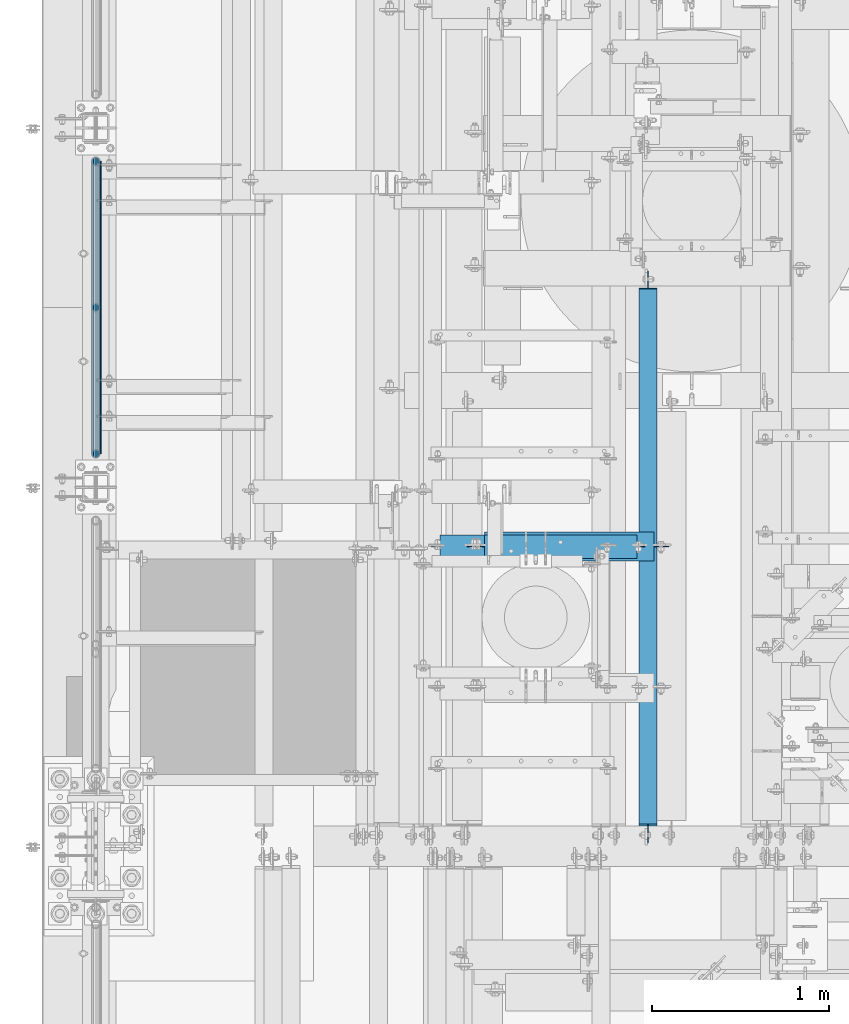
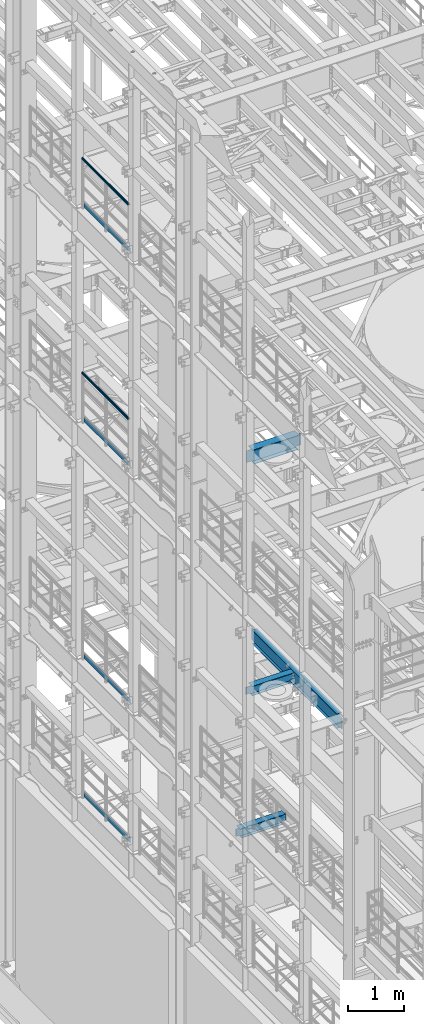
# One storey, part 1019 of 1876: 10 beams, 8 elements without a shape of their own.
"""IFC2X3 building model written with IfcOpenShell, lengths in millimetres."""

from ifc_helpers import new_model, si_unit, frame, origin_with_axes, place, context, subcontext, project, spatial, faceted_brep, material, type_object, element, aggregate, save


model = new_model("IFC2X3")

# Units and contexts
model_context = context("Model", 3, precision=1e-05, world=origin_with_axes())
body_context = subcontext(model_context, "Body", "Model", "MODEL_VIEW")
ifc_project = project(units=[si_unit("LENGTHUNIT", "METRE", prefix="MILLI"), si_unit("AREAUNIT", "SQUARE_METRE"), si_unit("VOLUMEUNIT", "CUBIC_METRE"), si_unit("MASSUNIT", "GRAM", prefix="KILO"), si_unit("TIMEUNIT", "SECOND"), si_unit("PLANEANGLEUNIT", "RADIAN"), si_unit("SOLIDANGLEUNIT", "STERADIAN"), si_unit("THERMODYNAMICTEMPERATUREUNIT", "DEGREE_CELSIUS"), si_unit("LUMINOUSINTENSITYUNIT", "LUMEN")], contexts=[model_context])

# Site, building, storey
site_placement = place(None, origin_with_axes())
site = spatial("IfcSite", under=ifc_project, at=site_placement, CompositionType="ELEMENT")
building_placement = place(site_placement, origin_with_axes())
building = spatial("IfcBuilding", under=site, at=building_placement, Name="Undefined", CompositionType="ELEMENT")
storey_placement = place(building_placement, origin_with_axes())
storey = spatial("IfcBuildingStorey", under=building, at=storey_placement, Name="Undefined", CompositionType="ELEMENT", Elevation=0.0)

# Assembly, beam
assembly_1_placement = place(storey_placement, origin_with_axes())
assembly_1 = element("IfcElementAssembly", 1, at=assembly_1_placement, inside=storey, Name="RAIL", AssemblyPlace="NOTDEFINED", PredefinedType="RIGID_FRAME")
ifc_material_1 = material()
beam_type_1 = type_object("IfcBeamType", Name="PIPE1-1/2SCH40", PredefinedType="NOTDEFINED")
beam_1_placement = place(assembly_1_placement, frame((-1.81898940354586e-12, 3721.1, 19059.525), z_axis=(0.0, 0.0, -1.0), x_axis=(0.0, 1.0, 0.0)))
beam_1 = element("IfcBeam", 2, at=beam_1_placement, type_object=beam_type_1, material=ifc_material_1, Name="RAIL", ObjectType="PIPE1-1/2SCH40", context=body_context, shape_type="Brep", body=[
    faceted_brep([(24.1300000000001, -20.4469999999999, 0.0), (34.3535000000002, -17.7076214311803, 10.2235000000001), (1667.4465, -17.7076214311801, 10.2235000000001), (1677.67, -20.4470000000001, 0.0), (41.8376214311802, -10.2235000000001, 17.7076214311819), (1659.96237856882, -10.2235000000001, 17.7076214311819), (44.5770000000002, 0.0, 20.4470000000001), (1657.223, 0.0, 20.4470000000001), (41.8376214311802, 10.2235000000001, 17.7076214311819), (1659.96237856882, 10.2235000000001, 17.7076214311819), (34.3535000000002, 17.7076214311803, 10.2235000000001), (1667.4465, 17.7076214311801, 10.2235000000001), (24.1300000000001, 20.4469999999999, 0.0), (1677.67, 20.4470000000001, 0.0), (13.9065000000001, 17.7076214311803, -10.2235000000001), (1687.8935, 17.7076214311801, -10.2235000000001), (6.42237856882002, 10.2235000000001, -17.7076214311819), (1695.37762143118, 10.2235000000001, -17.7076214311819), (3.68299999999999, 0.0, -20.4470000000001), (1698.117, 0.0, -20.4470000000001), (6.42237856882002, -10.2235000000001, -17.7076214311819), (1695.37762143118, -10.2235000000001, -17.7076214311819), (13.9065000000001, -17.7076214311803, -10.2235000000001), (1687.8935, -17.7076214311801, -10.2235000000001), (24.1299999999854, -24.1299999999992, 0.0), (12.0650000000064, -20.8971929933177, -12.0649999999987), (1689.735, -20.8971929933186, -12.0649999999987), (1677.67, -24.1300000000001, 0.0), (3.23280700668147, -12.0650000000001, -20.8971929933177), (1698.56719299332, -12.0649999999996, -20.8971929933177), (-1.45519152283669e-11, 0.0, -24.130000000001), (1701.8, 0.0, -24.130000000001), (3.23280700668147, 12.0650000000001, -20.8971929933177), (1698.56719299332, 12.0649999999996, -20.8971929933177), (12.0650000000064, 20.8971929933177, -12.0649999999987), (1689.735, 20.8971929933186, -12.0649999999987), (24.1300000000047, 24.1299999999992, 0.0), (1677.67, 24.1300000000001, 0.0), (36.1949999999997, 20.8971929933184, 12.0649999999987), (1665.605, 20.8971929933186, 12.0649999999987), (45.0271929933187, 12.0650000000001, 20.8971929933177), (1656.77280700668, 12.0649999999996, 20.8971929933177), (48.2600000000002, 0.0, 24.130000000001), (1653.54, 0.0, 24.130000000001), (45.0271929933187, -12.0650000000001, 20.8971929933177), (1656.77280700668, -12.0649999999996, 20.8971929933177), (36.1949999999997, -20.8971929933184, 12.0649999999987), (1665.605, -20.8971929933186, 12.0649999999987)], [[[0, 1, 2, 3]], [[1, 4, 5, 2]], [[4, 6, 7, 5]], [[6, 8, 9, 7]], [[8, 10, 11, 9]], [[10, 12, 13, 11]], [[12, 14, 15, 13]], [[14, 16, 17, 15]], [[16, 18, 19, 17]], [[18, 20, 21, 19]], [[20, 22, 23, 21]], [[22, 0, 3, 23]], [[24, 25, 26, 27]], [[25, 28, 29, 26]], [[28, 30, 31, 29]], [[30, 32, 33, 31]], [[32, 34, 35, 33]], [[34, 36, 37, 35]], [[36, 38, 39, 37]], [[38, 40, 41, 39]], [[40, 42, 43, 41]], [[42, 44, 45, 43]], [[44, 46, 47, 45]], [[46, 24, 27, 47]], [[29, 31, 33, 35, 37, 39, 41, 43, 45, 47, 27, 26], [5, 7, 9, 11, 13, 15, 17, 19, 21, 23, 3, 2]], [[46, 44, 42, 40, 38, 36, 34, 32, 30, 28, 25, 24], [22, 20, 18, 16, 14, 12, 10, 8, 6, 4, 1, 0]]]),
])

assembly_2_placement = place(storey_placement, origin_with_axes())
assembly_2 = element("IfcElementAssembly", 3, at=assembly_2_placement, inside=storey, Name="RAIL", AssemblyPlace="NOTDEFINED", PredefinedType="RIGID_FRAME")
beam_2_placement = place(assembly_2_placement, frame((-1.81898940354586e-12, 3721.1, 14385.925), z_axis=(0.0, 0.0, -1.0), x_axis=(0.0, 1.0, 0.0)))
beam_2 = element("IfcBeam", 4, at=beam_2_placement, type_object=beam_type_1, material=ifc_material_1, Name="RAIL", ObjectType="PIPE1-1/2SCH40", context=body_context, shape_type="Brep", body=[
    faceted_brep([(24.1300000000001, -20.4469999999999, 0.0), (34.3535000000002, -17.7076214311803, 10.2235000000001), (1667.4465, -17.7076214311801, 10.2235000000001), (1677.67, -20.4470000000001, 0.0), (41.8376214311802, -10.2235000000001, 17.7076214311819), (1659.96237856882, -10.2235000000001, 17.7076214311819), (44.5770000000002, 0.0, 20.4470000000001), (1657.223, 0.0, 20.4470000000001), (41.8376214311802, 10.2235000000001, 17.7076214311819), (1659.96237856882, 10.2235000000001, 17.7076214311819), (34.3535000000002, 17.7076214311803, 10.2235000000001), (1667.4465, 17.7076214311801, 10.2235000000001), (24.1300000000001, 20.4469999999999, 0.0), (1677.67, 20.4470000000001, 0.0), (13.9065000000001, 17.7076214311803, -10.2235000000001), (1687.8935, 17.7076214311801, -10.2235000000001), (6.42237856882002, 10.2235000000001, -17.7076214311819), (1695.37762143118, 10.2235000000001, -17.7076214311819), (3.68299999999999, 0.0, -20.4470000000001), (1698.117, 0.0, -20.4470000000001), (6.42237856882002, -10.2235000000001, -17.7076214311819), (1695.37762143118, -10.2235000000001, -17.7076214311819), (13.9065000000001, -17.7076214311803, -10.2235000000001), (1687.8935, -17.7076214311801, -10.2235000000001), (24.1299999999854, -24.1299999999992, 0.0), (12.0650000000064, -20.8971929933177, -12.0649999999987), (1689.735, -20.8971929933186, -12.0649999999987), (1677.67, -24.1300000000001, 0.0), (3.23280700668147, -12.0650000000001, -20.8971929933177), (1698.56719299332, -12.0649999999996, -20.8971929933177), (-1.45519152283669e-11, 0.0, -24.130000000001), (1701.8, 0.0, -24.130000000001), (3.23280700668147, 12.0650000000001, -20.8971929933177), (1698.56719299332, 12.0649999999996, -20.8971929933177), (12.0650000000064, 20.8971929933177, -12.0649999999987), (1689.735, 20.8971929933186, -12.0649999999987), (24.1300000000047, 24.1299999999992, 0.0), (1677.67, 24.1300000000001, 0.0), (36.1949999999997, 20.8971929933184, 12.0649999999987), (1665.605, 20.8971929933186, 12.0649999999987), (45.0271929933187, 12.0650000000001, 20.8971929933177), (1656.77280700668, 12.0649999999996, 20.8971929933177), (48.2600000000002, 0.0, 24.130000000001), (1653.54, 0.0, 24.130000000001), (45.0271929933187, -12.0650000000001, 20.8971929933177), (1656.77280700668, -12.0649999999996, 20.8971929933177), (36.1949999999997, -20.8971929933184, 12.0649999999987), (1665.605, -20.8971929933186, 12.0649999999987)], [[[0, 1, 2, 3]], [[1, 4, 5, 2]], [[4, 6, 7, 5]], [[6, 8, 9, 7]], [[8, 10, 11, 9]], [[10, 12, 13, 11]], [[12, 14, 15, 13]], [[14, 16, 17, 15]], [[16, 18, 19, 17]], [[18, 20, 21, 19]], [[20, 22, 23, 21]], [[22, 0, 3, 23]], [[24, 25, 26, 27]], [[25, 28, 29, 26]], [[28, 30, 31, 29]], [[30, 32, 33, 31]], [[32, 34, 35, 33]], [[34, 36, 37, 35]], [[36, 38, 39, 37]], [[38, 40, 41, 39]], [[40, 42, 43, 41]], [[42, 44, 45, 43]], [[44, 46, 47, 45]], [[46, 24, 27, 47]], [[29, 31, 33, 35, 37, 39, 41, 43, 45, 47, 27, 26], [5, 7, 9, 11, 13, 15, 17, 19, 21, 23, 3, 2]], [[46, 44, 42, 40, 38, 36, 34, 32, 30, 28, 25, 24], [22, 20, 18, 16, 14, 12, 10, 8, 6, 4, 1, 0]]]),
])

# Beam
ifc_material_2 = material(Name="STEEL/A36")
beam_type_2 = type_object("IfcBeamType", PredefinedType="NOTDEFINED")
beam_3_placement = place(assembly_1_placement, frame((27.3049999999948, 3745.23, 18049.875), z_axis=(0.0, 0.0, 1.0), x_axis=(0.0, 1.0, 0.0)))
beam_3 = element("IfcBeam", 5, at=beam_3_placement, type_object=beam_type_2, material=ifc_material_2, Name="PLATE", context=body_context, shape_type="Brep", body=[
    faceted_brep([(0.0, 3.17500000000018, -50.8000000000002), (0.0, 3.17500000000018, 50.8000000000002), (1653.54, 3.175, 50.7999999999993), (1653.54, 3.175, -50.7999999999993), (0.0, -3.17500000000018, 50.8000000000002), (1653.54, -3.175, 50.7999999999993), (0.0, -3.17500000000018, -50.8000000000002), (1653.54, -3.175, -50.7999999999993)], [[[0, 1, 2, 3]], [[1, 4, 5, 2]], [[4, 6, 7, 5]], [[6, 0, 3, 7]], [[5, 7, 3, 2]], [[6, 4, 1, 0]]]),
])

aggregate(assembly_1, [beam_3, beam_1])

beam_4_placement = place(assembly_2_placement, frame((27.3049999999948, 3745.23, 13376.275), z_axis=(0.0, 0.0, 1.0), x_axis=(0.0, 1.0, 0.0)))
beam_4 = element("IfcBeam", 6, at=beam_4_placement, type_object=beam_type_2, material=ifc_material_2, Name="PLATE", context=body_context, shape_type="Brep", body=[
    faceted_brep([(0.0, 3.17500000000018, -50.8000000000002), (0.0, 3.17500000000018, 50.8000000000002), (1653.54, 3.175, 50.7999999999993), (1653.54, 3.175, -50.7999999999993), (0.0, -3.17500000000018, 50.8000000000002), (1653.54, -3.175, 50.7999999999993), (0.0, -3.17500000000018, -50.8000000000002), (1653.54, -3.175, -50.7999999999993)], [[[0, 1, 2, 3]], [[1, 4, 5, 2]], [[4, 6, 7, 5]], [[6, 0, 3, 7]], [[5, 7, 3, 2]], [[6, 4, 1, 0]]]),
])

aggregate(assembly_2, [beam_4, beam_2])

# Assembly, beam
assembly_3_placement = place(storey_placement, origin_with_axes())
assembly_3 = element("IfcElementAssembly", 7, at=assembly_3_placement, inside=storey, Name="RAIL", AssemblyPlace="NOTDEFINED", PredefinedType="RIGID_FRAME")
beam_5_placement = place(assembly_3_placement, frame((27.3049999999948, 3745.23000000001, 8220.075), z_axis=(0.0, 0.0, 1.0), x_axis=(0.0, 1.0, 0.0)))
beam_5 = element("IfcBeam", 8, at=beam_5_placement, type_object=beam_type_2, material=ifc_material_2, Name="PLATE", context=body_context, shape_type="Brep", body=[
    faceted_brep([(0.0, 3.17500000000018, -50.8000000000002), (0.0, 3.17500000000018, 50.8000000000002), (1653.54, 3.175, 50.7999999999993), (1653.54, 3.175, -50.7999999999993), (0.0, -3.17500000000018, 50.8000000000002), (1653.54, -3.175, 50.7999999999993), (0.0, -3.17500000000018, -50.8000000000002), (1653.54, -3.175, -50.7999999999993)], [[[0, 1, 2, 3]], [[1, 4, 5, 2]], [[4, 6, 7, 5]], [[6, 0, 3, 7]], [[5, 7, 3, 2]], [[6, 4, 1, 0]]]),
])
aggregate(assembly_3, [beam_5])

assembly_4_placement = place(storey_placement, origin_with_axes())
assembly_4 = element("IfcElementAssembly", 9, at=assembly_4_placement, inside=storey, Name="RAIL", AssemblyPlace="NOTDEFINED", PredefinedType="RIGID_FRAME")
beam_6_placement = place(assembly_4_placement, frame((27.3049999999948, 3745.23, 5197.475), z_axis=(0.0, 0.0, 1.0), x_axis=(0.0, 1.0, 0.0)))
beam_6 = element("IfcBeam", 10, at=beam_6_placement, type_object=beam_type_2, material=ifc_material_2, Name="PLATE", context=body_context, shape_type="Brep", body=[
    faceted_brep([(0.0, 3.17500000000018, -50.8000000000002), (0.0, 3.17500000000018, 50.8000000000002), (1653.54, 3.175, 50.7999999999993), (1653.54, 3.175, -50.7999999999993), (0.0, -3.17500000000018, 50.8000000000002), (1653.54, -3.175, 50.7999999999993), (0.0, -3.17500000000018, -50.8000000000002), (1653.54, -3.175, -50.7999999999993)], [[[0, 1, 2, 3]], [[1, 4, 5, 2]], [[4, 6, 7, 5]], [[6, 0, 3, 7]], [[5, 7, 3, 2]], [[6, 4, 1, 0]]]),
])
aggregate(assembly_4, [beam_6])

assembly_5_placement = place(storey_placement, origin_with_axes())
assembly_5 = element("IfcElementAssembly", 11, at=assembly_5_placement, inside=storey, Name="BEAM", AssemblyPlace="NOTDEFINED", PredefinedType="RIGID_FRAME")
ifc_material_3 = material(Name="STEEL/A992")
beam_type_3 = type_object("IfcBeamType", Name="W12X16", PredefinedType="NOTDEFINED")
beam_7_placement = place(assembly_5_placement, frame((3124.2, 1524.0, 8001.0), z_axis=(0.0, 0.0, 1.0), x_axis=(0.0, 1.0, 0.0)))
beam_7 = element("IfcBeam", 12, at=beam_7_placement, type_object=beam_type_3, material=ifc_material_3, Name="BEAM", ObjectType="W12X16", context=body_context, shape_type="Brep", body=[
    faceted_brep([(3158.33125000001, -3.17500000000018, -146.05), (3158.33125000001, -50.8000000000002, -146.05), (3158.33125000001, -50.8000000000002, -152.4), (3158.33125000001, 50.8000000000002, -152.4), (3158.33125000001, 50.8000000000002, -146.05), (3158.33125000001, 3.17500000000018, -146.05), (3158.33125000001, 3.17500000000018, -139.699999809265), (3158.33125000001, -3.17500000000018, -139.699999809265), (3159.29797992259, 3.17500000000018, -134.83992029122), (3159.29797992259, -3.17500000000018, -134.83992029122), (3162.05099382307, 3.17500000000018, -130.719743823066), (3162.05099382307, -3.17500000000018, -130.719743823066), (3166.17117029123, 3.17500000000018, -127.966729922588), (3166.17117029123, -3.17500000000018, -127.966729922588), (3171.03124980927, 3.17500000000018, -127.0), (3171.03124980927, -3.17500000000018, -127.0), (3253.58125000001, -3.17500000000018, -127.0), (3253.58125000001, 3.17500000000018, -127.0), (127.79375, 3.17500000000018, 146.05), (127.79375, 50.8000000000002, 146.05), (3151.98125000001, 50.8000000000002, 146.05), (3151.98125000001, 3.17500000000018, 146.05), (115.09375, -3.17500000000018, -139.699999809266), (115.09375, 3.17500000000018, -139.699999809266), (115.09375, 3.17500000000018, -146.05), (115.09375, 50.8000000000002, -146.05), (115.09375, 50.8000000000002, -152.4), (115.09375, -50.8000000000002, -152.4), (115.09375, -50.8000000000002, -146.05), (115.09375, -3.17500000000018, -146.05), (114.127020077412, -3.17500000000018, -134.839920291221), (114.127020077412, 3.17500000000018, -134.839920291221), (111.374006176934, -3.17500000000018, -130.719743823067), (111.374006176934, 3.17500000000018, -130.719743823067), (107.25382970878, -3.17500000000018, -127.966729922588), (107.25382970878, 3.17500000000018, -127.966729922588), (102.393750190735, -3.17500000000018, -127.000000000001), (102.393750190735, 3.17500000000018, -127.000000000001), (19.84375, -3.17499999999995, -126.999999999996), (19.84375, 3.17499999999995, -126.999999999996), (19.84375, -3.17500000000018, 114.299999999999), (19.84375, 3.17500000000018, 114.299999999999), (115.093750190735, -3.17500000000018, 114.299999999999), (115.093750190735, 3.17500000000018, 114.299999999999), (119.95382970878, -3.17500000000018, 115.266729922587), (119.95382970878, 3.17500000000018, 115.266729922587), (124.074006176934, -3.17500000000018, 118.019743823065), (124.074006176934, 3.17500000000018, 118.019743823065), (126.827020077412, -3.17500000000018, 122.139920291219), (126.827020077412, 3.17500000000018, 122.139920291219), (127.79375, -3.17500000000018, 126.999999809264), (127.79375, 3.17500000000018, 126.999999809264), (127.79375, -50.8000000000002, 152.4), (127.79375, 50.8000000000002, 152.4), (127.79375, -3.17500000000018, 146.05), (127.79375, -50.8000000000002, 146.05), (3151.98125000001, -3.17500000000018, 146.05), (3151.98125000001, -50.8000000000002, 146.05), (3151.98125000001, -50.8000000000002, 152.4), (3151.98125000001, 50.8000000000002, 152.4), (3151.98125000001, -3.17500000000018, 139.699999809265), (3151.98125000001, 3.17500000000018, 139.699999809265), (3152.94797992259, -3.17500000000018, 134.83992029122), (3152.94797992259, 3.17500000000018, 134.83992029122), (3155.70099382307, -3.17500000000018, 130.719743823066), (3155.70099382307, 3.17500000000018, 130.719743823066), (3159.82117029122, -3.17500000000018, 127.966729922588), (3159.82117029122, 3.17500000000018, 127.966729922588), (3164.68124980927, -3.17500000000018, 127.0), (3164.68124980927, 3.17500000000018, 127.0), (3253.58125000001, -3.17500000000018, 127.0), (3253.58125000001, 3.17500000000018, 127.0)], [[[0, 1, 2, 3, 4, 5, 6, 7]], [[7, 6, 8, 9]], [[9, 8, 10, 11]], [[11, 10, 12, 13]], [[13, 12, 14, 15]], [[16, 15, 14, 17]], [[18, 19, 20, 21]], [[22, 23, 24, 25, 26, 27, 28, 29]], [[30, 31, 23, 22]], [[32, 33, 31, 30]], [[34, 35, 33, 32]], [[36, 37, 35, 34]], [[38, 39, 37, 36]], [[40, 41, 39, 38]], [[42, 43, 41, 40]], [[44, 45, 43, 42]], [[46, 47, 45, 44]], [[48, 49, 47, 46]], [[50, 51, 49, 48]], [[52, 53, 19, 18, 51, 50, 54, 55]], [[55, 54, 56, 57]], [[52, 55, 57, 58]], [[53, 52, 58, 59]], [[19, 53, 59, 20]], [[58, 57, 56, 60, 61, 21, 20, 59]], [[62, 63, 61, 60]], [[64, 65, 63, 62]], [[66, 67, 65, 64]], [[68, 69, 67, 66]], [[70, 71, 69, 68]], [[71, 70, 16, 17]], [[12, 10, 8, 6, 5, 24, 23, 31, 33, 35, 37, 39, 41, 43, 45, 47, 49, 51, 18, 21, 61, 63, 65, 67, 69, 71, 17, 14]], [[25, 24, 5, 4]], [[26, 25, 4, 3]], [[27, 26, 3, 2]], [[28, 27, 2, 1]], [[29, 28, 1, 0]], [[70, 68, 66, 64, 62, 60, 56, 54, 50, 48, 46, 44, 42, 40, 38, 36, 34, 32, 30, 22, 29, 0, 7, 9, 11, 13, 15, 16]]]),
])
aggregate(assembly_5, [beam_7])

assembly_6_placement = place(storey_placement, origin_with_axes())
assembly_6 = element("IfcElementAssembly", 13, at=assembly_6_placement, inside=storey, Name="BEAM", AssemblyPlace="NOTDEFINED", PredefinedType="RIGID_FRAME")
beam_type_4 = type_object("IfcBeamType", Name="W8X18", PredefinedType="NOTDEFINED")
beam_8_placement = place(assembly_6_placement, frame((2089.15, 3219.45, 8050.2125), z_axis=(0.0, 0.0, 1.0), x_axis=(1.0, 0.0, 0.0)))
beam_8 = element("IfcBeam", 14, at=beam_8_placement, type_object=beam_type_4, material=ifc_material_3, Name="BEAM", ObjectType="W8X18", context=body_context, shape_type="Brep", body=[
    faceted_brep([(10.3187500000004, -3.17500000000018, -77.7874999999995), (10.3187500000004, 3.17500000000018, -77.7874999999995), (96.043750190735, 3.17499999999927, -77.7875000000004), (96.043750190735, -3.17499999999927, -77.7875000000004), (100.903829708781, 3.17499999999927, -78.7542299225879), (100.903829708781, -3.17499999999927, -78.7542299225879), (105.024006176934, 3.17499999999927, -81.5072438230654), (105.024006176934, -3.17499999999927, -81.5072438230654), (107.777020077412, 3.17499999999927, -85.6274202912191), (107.777020077412, -3.17499999999927, -85.6274202912191), (108.74375, -3.17499999999927, -90.4874998092655), (108.74375, 3.17499999999927, -90.4874998092655), (108.74375, 3.17499999999927, -95.25), (108.74375, 66.6749999999993, -95.25), (108.74375, 66.6750000000002, -103.1875), (108.74375, -66.6750000000002, -103.1875), (108.74375, -66.6749999999993, -95.25), (108.74375, -3.17499999999927, -95.25), (971.550000000001, 66.6750000000002, 95.25), (971.550000000001, 3.17500000000018, 95.25), (108.743750000001, 3.17500000000018, 95.25), (108.743750000001, 66.6750000000002, 95.25), (96.0437501907354, -3.17500000000018, 77.7875000000004), (96.0437501907354, 3.17500000000018, 77.7875000000004), (10.3187500000004, 3.17500000000018, 77.7875000000004), (10.3187500000004, -3.17500000000018, 77.7875000000004), (100.903829708781, -3.17500000000018, 78.7542299225879), (100.903829708781, 3.17500000000018, 78.7542299225879), (105.024006176935, -3.17500000000018, 81.5072438230663), (105.024006176935, 3.17500000000018, 81.5072438230663), (107.777020077413, -3.17500000000018, 85.62742029122), (107.777020077413, 3.17500000000018, 85.62742029122), (108.743750000001, -3.17500000000018, 90.4874998092655), (108.743750000001, 3.17500000000018, 90.4874998092655), (971.550000000001, -66.6750000000002, 103.1875), (971.550000000001, 66.6750000000002, 103.1875), (108.743750000001, 66.6750000000002, 103.1875), (108.743750000001, -66.6750000000002, 103.1875), (971.550000000001, -66.6750000000002, 95.25), (108.743750000001, -66.6750000000002, 95.25), (971.550000000001, -3.17500000000018, 95.25), (108.743750000001, -3.17500000000018, 95.25), (971.550000000001, -3.17500000000018, 90.4874998092646), (971.550000000001, 3.17500000000018, 90.4874998092646), (972.516729922589, -3.17500000000018, 85.6274202912191), (972.516729922589, 3.17500000000018, 85.6274202912191), (975.269743823067, -3.17500000000018, 81.5072438230654), (975.269743823067, 3.17500000000018, 81.5072438230654), (979.389920291221, -3.17500000000018, 78.754229922587), (979.389920291221, 3.17500000000018, 78.754229922587), (984.249999809266, -3.17500000000018, 77.7874999999995), (984.249999809266, 3.17500000000018, 77.7874999999995), (1019.175, -3.17500000000018, 77.7874999999995), (1019.175, 3.17500000000018, 77.7874999999995), (1019.175, -3.17500000000018, -77.7875000000004), (1019.175, 3.17500000000018, -77.7875000000004), (936.624999809266, -3.17500000000018, -77.7875000000004), (936.624999809266, 3.17500000000018, -77.7875000000004), (931.764920291221, -3.17500000000018, -78.7542299225879), (931.764920291221, 3.17500000000018, -78.7542299225879), (927.644743823067, -3.17500000000018, -81.5072438230663), (927.644743823067, 3.17500000000018, -81.5072438230663), (924.891729922589, -3.17500000000018, -85.62742029122), (924.891729922589, 3.17500000000018, -85.62742029122), (923.925000000001, -3.17500000000018, -90.4874998092655), (923.925000000001, 3.17500000000018, -90.4874998092655), (923.925000000001, -3.17500000000018, -95.25), (923.925000000001, -66.6750000000002, -95.25), (923.925000000001, -66.6750000000002, -103.1875), (923.925000000001, 66.6750000000002, -103.1875), (923.925000000001, 66.6750000000002, -95.25), (923.925000000001, 3.17500000000018, -95.25)], [[[0, 1, 2, 3]], [[3, 2, 4, 5]], [[5, 4, 6, 7]], [[7, 6, 8, 9]], [[10, 11, 12, 13, 14, 15, 16, 17]], [[9, 8, 11, 10]], [[18, 19, 20, 21]], [[22, 23, 24, 25]], [[26, 27, 23, 22]], [[28, 29, 27, 26]], [[30, 31, 29, 28]], [[32, 33, 31, 30]], [[34, 35, 36, 37]], [[38, 34, 37, 39]], [[40, 38, 39, 41]], [[37, 36, 21, 20, 33, 32, 41, 39]], [[35, 18, 21, 36]], [[34, 38, 40, 42, 43, 19, 18, 35]], [[44, 45, 43, 42]], [[46, 47, 45, 44]], [[48, 49, 47, 46]], [[50, 51, 49, 48]], [[52, 53, 51, 50]], [[53, 52, 54, 55]], [[54, 56, 57, 55]], [[58, 59, 57, 56]], [[60, 61, 59, 58]], [[62, 63, 61, 60]], [[64, 65, 63, 62]], [[66, 67, 68, 69, 70, 71, 65, 64]], [[67, 66, 17, 16]], [[68, 67, 16, 15]], [[69, 68, 15, 14]], [[70, 69, 14, 13]], [[71, 70, 13, 12]], [[6, 4, 2, 1, 24, 23, 27, 29, 31, 33, 20, 19, 43, 45, 47, 49, 51, 53, 55, 57, 59, 61, 63, 65, 71, 12, 11, 8]], [[25, 24, 1, 0]], [[66, 64, 62, 60, 58, 56, 54, 52, 50, 48, 46, 44, 42, 40, 41, 32, 30, 28, 26, 22, 25, 0, 3, 5, 7, 9, 10, 17]]]),
])
aggregate(assembly_6, [beam_8])

assembly_7_placement = place(storey_placement, origin_with_axes())
assembly_7 = element("IfcElementAssembly", 15, at=assembly_7_placement, inside=storey, Name="BEAM", AssemblyPlace="NOTDEFINED", PredefinedType="RIGID_FRAME")
beam_9_placement = place(assembly_7_placement, frame((1930.4, 3219.45, 5027.6125), z_axis=(0.0, 0.0, -1.0), x_axis=(1.0, 0.0, 0.0)))
beam_9 = element("IfcBeam", 16, at=beam_9_placement, type_object=beam_type_4, material=ifc_material_3, Name="BEAM", ObjectType="W8X18", context=body_context, shape_type="Brep", body=[
    faceted_brep([(-34.9249999999995, -3.17500000000018, -84.1374999999989), (-34.9249999999995, 3.17500000000018, -84.1374999999989), (3.17500019073532, 3.17500000000018, -84.1374999999989), (3.17500019073532, -3.17500000000018, -84.1374999999989), (8.03507970878081, 3.17500000000018, -85.1042299225865), (8.03507970878081, -3.17500000000018, -85.1042299225865), (12.1552561769345, 3.17500000000018, -87.8572438230649), (12.1552561769345, -3.17500000000018, -87.8572438230649), (14.9082700774127, 3.17500000000018, -91.9774202912186), (14.9082700774127, -3.17500000000018, -91.9774202912186), (15.8750000000005, -66.6750000000002, -96.837499809264), (15.8750000000005, 66.6750000000002, -96.837499809264), (15.8750000000005, 66.6750000000002, -103.1875), (15.8750000000005, -66.6750000000002, -103.1875), (15.5592266547251, -66.6750000000002, -95.25), (15.5592266547251, -3.17500000000018, -95.25), (15.5592266547251, 3.17500000000018, -95.25), (15.5592266547251, 66.6750000000002, -95.25), (53.9750000000006, 3.17500000000018, 95.25), (53.9750000000006, 66.6750000000002, 95.25), (911.225000000001, 66.6750000000002, 95.25), (911.225000000001, 3.17500000000018, 95.25), (41.2750001907355, -3.17500000000018, 77.7875000000013), (41.2750001907355, 3.17500000000018, 77.7875000000013), (-34.9249999999995, 3.17500000000018, 77.7875000000013), (-34.9249999999995, -3.17500000000018, 77.7875000000013), (46.1350797087809, -3.17500000000018, 78.7542299225888), (46.1350797087809, 3.17500000000018, 78.7542299225888), (50.2552561769346, -3.17500000000018, 81.5072438230673), (50.2552561769346, 3.17500000000018, 81.5072438230673), (53.0082700774128, -3.17500000000018, 85.6274202912209), (53.0082700774128, 3.17500000000018, 85.6274202912209), (53.9750000000006, -3.17500000000018, 90.4874998092664), (53.9750000000006, 3.17500000000018, 90.4874998092664), (53.9750000000006, -66.6750000000002, 103.1875), (53.9750000000006, 66.6750000000002, 103.1875), (53.9750000000006, -3.17500000000018, 95.25), (53.9750000000006, -66.6750000000002, 95.25), (911.225000000001, -3.17500000000018, 95.25), (911.225000000001, -66.6750000000002, 95.25), (911.225000000001, -66.6750000000002, 103.1875), (911.225000000001, 66.6750000000002, 103.1875), (911.225000000001, -3.17500000000018, 90.4874998092664), (911.225000000001, 3.17500000000018, 90.4874998092664), (912.191729922589, -3.17500000000018, 85.6274202912209), (912.191729922589, 3.17500000000018, 85.6274202912209), (914.944743823067, -3.17500000000018, 81.5072438230673), (914.944743823067, 3.17500000000018, 81.5072438230673), (919.06492029122, -3.17500000000018, 78.7542299225888), (919.06492029122, 3.17500000000018, 78.7542299225888), (923.924999809266, -3.17500000000018, 77.7875000000013), (923.924999809266, 3.17500000000018, 77.7875000000013), (1000.125, -3.17500000000018, 77.7875000000013), (1000.125, 3.17500000000018, 77.7875000000013), (1000.125, -3.17500000000018, -84.1374999999989), (1000.125, 3.17500000000018, -84.1374999999989), (962.024999809266, -3.17500000000018, -84.1374999999989), (962.024999809266, 3.17500000000018, -84.1374999999989), (957.16492029122, -3.17500000000018, -85.1042299225865), (957.16492029122, 3.17500000000018, -85.1042299225865), (953.044743823067, -3.17500000000018, -87.8572438230649), (953.044743823067, 3.17500000000018, -87.8572438230649), (950.291729922589, -3.17500000000018, -91.9774202912186), (950.291729922589, 3.17500000000018, -91.9774202912186), (949.640773345277, -3.17500000000018, -95.25), (949.640773345277, -66.6750000000002, -95.25), (949.325000000001, -66.6750000000002, -96.837499809264), (949.325000000001, 66.6750000000002, -96.837499809264), (949.640773345277, 66.6750000000002, -95.25), (949.640773345277, 3.17500000000018, -95.25), (949.325000000001, -66.6750000000002, -103.1875), (949.325000000001, 66.6750000000002, -103.1875)], [[[0, 1, 2, 3]], [[3, 2, 4, 5]], [[5, 4, 6, 7]], [[7, 6, 8, 9]], [[10, 11, 12, 13]], [[14, 15, 9, 8, 16, 17, 11, 10]], [[18, 19, 20, 21]], [[22, 23, 24, 25]], [[26, 27, 23, 22]], [[28, 29, 27, 26]], [[30, 31, 29, 28]], [[32, 33, 31, 30]], [[34, 35, 19, 18, 33, 32, 36, 37]], [[37, 36, 38, 39]], [[34, 37, 39, 40]], [[35, 34, 40, 41]], [[19, 35, 41, 20]], [[40, 39, 38, 42, 43, 21, 20, 41]], [[44, 45, 43, 42]], [[46, 47, 45, 44]], [[48, 49, 47, 46]], [[50, 51, 49, 48]], [[52, 53, 51, 50]], [[53, 52, 54, 55]], [[54, 56, 57, 55]], [[58, 59, 57, 56]], [[60, 61, 59, 58]], [[62, 63, 61, 60]], [[64, 65, 66, 67, 68, 69, 63, 62]], [[70, 71, 67, 66]], [[71, 70, 13, 12]], [[68, 67, 71, 12, 11, 17]], [[69, 68, 17, 16]], [[6, 4, 2, 1, 24, 23, 27, 29, 31, 33, 18, 21, 43, 45, 47, 49, 51, 53, 55, 57, 59, 61, 63, 69, 16, 8]], [[25, 24, 1, 0]], [[64, 62, 60, 58, 56, 54, 52, 50, 48, 46, 44, 42, 38, 36, 32, 30, 28, 26, 22, 25, 0, 3, 5, 7, 9, 15]], [[65, 64, 15, 14]], [[70, 66, 65, 14, 10, 13]]]),
])
aggregate(assembly_7, [beam_9])

assembly_8_placement = place(storey_placement, origin_with_axes())
assembly_8 = element("IfcElementAssembly", 17, at=assembly_8_placement, inside=storey, Name="BEAM", AssemblyPlace="NOTDEFINED", PredefinedType="RIGID_FRAME")
beam_type_5 = type_object("IfcBeamType", Name="W12X30", PredefinedType="NOTDEFINED")
beam_10_placement = place(assembly_8_placement, frame((2101.85, 3219.45, 13152.4375), z_axis=(0.0, 0.0, 1.0), x_axis=(1.0, 0.0, 0.0)))
beam_10 = element("IfcBeam", 18, at=beam_10_placement, type_object=beam_type_5, material=ifc_material_3, Name="BEAM", ObjectType="W12X30", context=body_context, shape_type="Brep", body=[
    faceted_brep([(1025.525, -3.17500000000018, -146.049999999999), (1025.525, -82.5500000000002, -146.049999999999), (1025.525, -82.5500000000002, -157.1625), (1025.525, 82.5500000000002, -157.1625), (1025.525, 82.5500000000002, -146.049999999999), (1025.525, 3.17500000000018, -146.049999999999), (1025.525, 3.17500000000018, -144.462499809264), (1025.525, -3.17500000000018, -144.462499809264), (1026.49172992259, 3.17500000000018, -139.602420291218), (1026.49172992259, -3.17500000000018, -139.602420291218), (1029.24474382307, 3.17500000000018, -135.482243823064), (1029.24474382307, -3.17500000000018, -135.482243823064), (1033.36492029122, 3.17500000000018, -132.729229922586), (1033.36492029122, -3.17500000000018, -132.729229922586), (1038.22499980927, 3.17500000000018, -131.762499999999), (1038.22499980927, -3.17500000000018, -131.762499999999), (1139.825, -3.17500000000018, -131.762499999999), (1139.825, 3.17500000000018, -131.762499999999), (98.4250000000029, 3.17500000000018, 146.049999999999), (98.4250000000002, 82.5500000000002, 146.049999999999), (1057.275, 82.5500000000002, 146.049999999999), (1057.275, 3.17500000000018, 146.049999999999), (130.175000000001, -3.17500000000018, -144.462499809264), (130.175000000001, 3.17500000000018, -144.462499809264), (130.175000000001, 3.17500000000018, -146.049999999999), (130.175000000001, 82.5500000000002, -146.049999999999), (130.175000000001, 82.5500000000002, -157.1625), (130.175000000001, -82.5500000000002, -157.1625), (130.175000000001, -82.5500000000002, -146.049999999999), (130.175000000001, -3.17500000000018, -146.049999999999), (129.208270077413, -3.17500000000018, -139.602420291218), (129.208270077413, 3.17500000000018, -139.602420291218), (126.455256176935, -3.17500000000018, -135.482243823064), (126.455256176935, 3.17500000000018, -135.482243823064), (122.335079708781, -3.17500000000018, -132.729229922586), (122.335079708781, 3.17500000000018, -132.729229922586), (117.475000190736, -3.17500000000018, -131.762499999999), (117.475000190736, 3.17500000000018, -131.762499999999), (15.875, -3.17500000000018, -131.762499999999), (15.875, 3.17500000000018, -131.762499999999), (15.875, -3.17500000000018, 125.4125), (15.875, 3.17500000000018, 125.4125), (85.725000190736, -3.17500000000018, 125.4125), (85.725000190736, 3.17500000000018, 125.4125), (90.5850797087814, -3.17500000000018, 126.379229922588), (90.5850797087814, 3.17500000000018, 126.379229922588), (94.7052561769351, -3.17500000000018, 129.132243823065), (94.7052561769351, 3.17500000000018, 129.132243823065), (97.4582700774131, -3.17500000000018, 133.252420291219), (97.4582700774131, 3.17500000000018, 133.252420291219), (98.4250000000011, -3.17500000000018, 138.112499809266), (98.4250000000011, 3.17500000000018, 138.112499809266), (98.4250000000011, -82.5500000000002, 157.1625), (98.4250000000011, 82.5500000000002, 157.1625), (98.4250000000029, -3.17500000000018, 146.049999999999), (98.4250000000002, -82.5500000000002, 146.049999999999), (1057.275, -3.17500000000018, 146.049999999999), (1057.275, -82.5500000000002, 146.049999999999), (1057.275, -82.5500000000002, 157.1625), (1057.275, 82.5500000000002, 157.1625), (1057.275, -3.17500000000018, 138.112499809266), (1057.275, 3.17500000000018, 138.112499809266), (1058.24172992259, -3.17500000000018, 133.252420291219), (1058.24172992259, 3.17500000000018, 133.252420291219), (1060.99474382307, -3.17500000000018, 129.132243823065), (1060.99474382307, 3.17500000000018, 129.132243823065), (1065.11492029122, -3.17500000000018, 126.379229922588), (1065.11492029122, 3.17500000000018, 126.379229922588), (1069.97499980927, -3.17500000000018, 125.4125), (1069.97499980927, 3.17500000000018, 125.4125), (1139.825, -3.17500000000018, 125.4125), (1139.825, 3.17500000000018, 125.4125)], [[[0, 1, 2, 3, 4, 5, 6, 7]], [[7, 6, 8, 9]], [[9, 8, 10, 11]], [[11, 10, 12, 13]], [[13, 12, 14, 15]], [[16, 15, 14, 17]], [[18, 19, 20, 21]], [[22, 23, 24, 25, 26, 27, 28, 29]], [[30, 31, 23, 22]], [[32, 33, 31, 30]], [[34, 35, 33, 32]], [[36, 37, 35, 34]], [[38, 39, 37, 36]], [[40, 41, 39, 38]], [[42, 43, 41, 40]], [[44, 45, 43, 42]], [[46, 47, 45, 44]], [[48, 49, 47, 46]], [[50, 51, 49, 48]], [[52, 53, 19, 18, 51, 50, 54, 55]], [[55, 54, 56, 57]], [[52, 55, 57, 58]], [[53, 52, 58, 59]], [[19, 53, 59, 20]], [[58, 57, 56, 60, 61, 21, 20, 59]], [[62, 63, 61, 60]], [[64, 65, 63, 62]], [[66, 67, 65, 64]], [[68, 69, 67, 66]], [[70, 71, 69, 68]], [[71, 70, 16, 17]], [[12, 10, 8, 6, 5, 24, 23, 31, 33, 35, 37, 39, 41, 43, 45, 47, 49, 51, 18, 21, 61, 63, 65, 67, 69, 71, 17, 14]], [[25, 24, 5, 4]], [[26, 25, 4, 3]], [[27, 26, 3, 2]], [[28, 27, 2, 1]], [[29, 28, 1, 0]], [[70, 68, 66, 64, 62, 60, 56, 54, 50, 48, 46, 44, 42, 40, 38, 36, 34, 32, 30, 22, 29, 0, 7, 9, 11, 13, 15, 16]]]),
])
aggregate(assembly_8, [beam_10])

save(model, "model.ifc")
